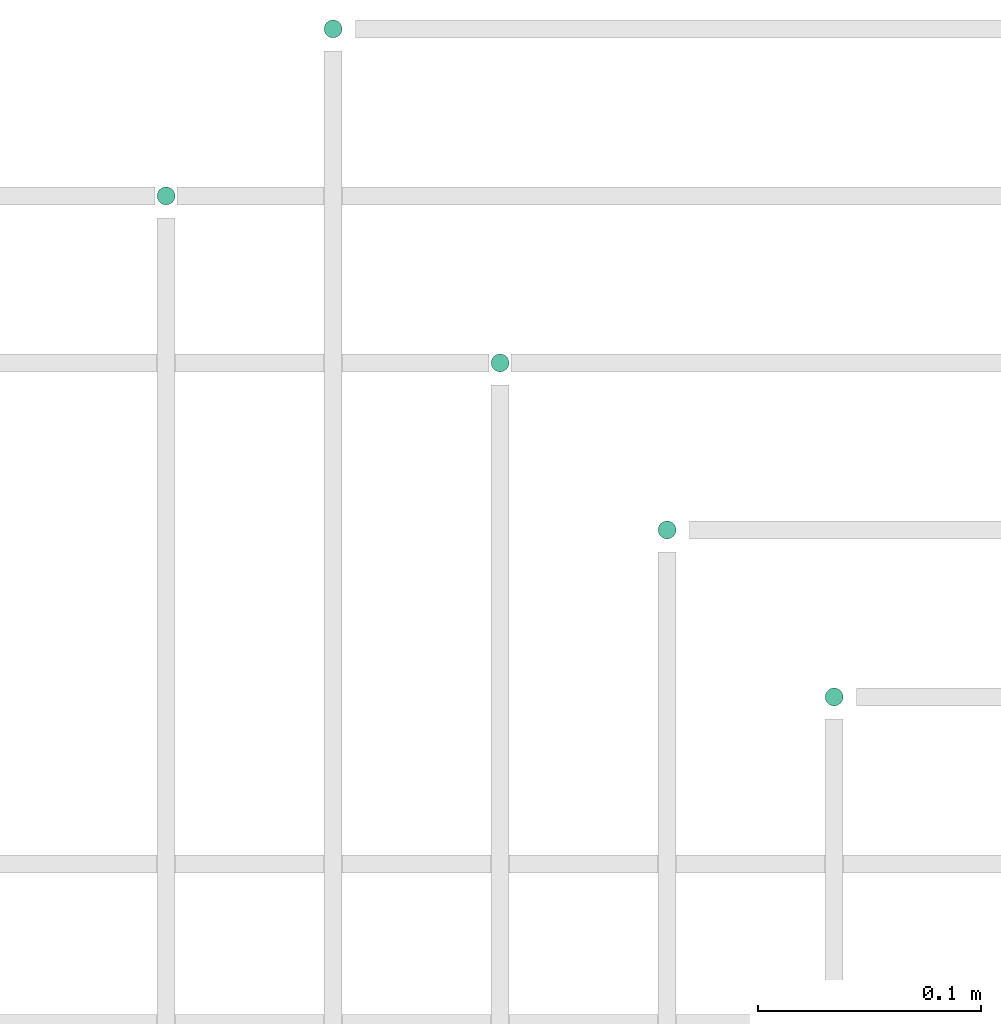
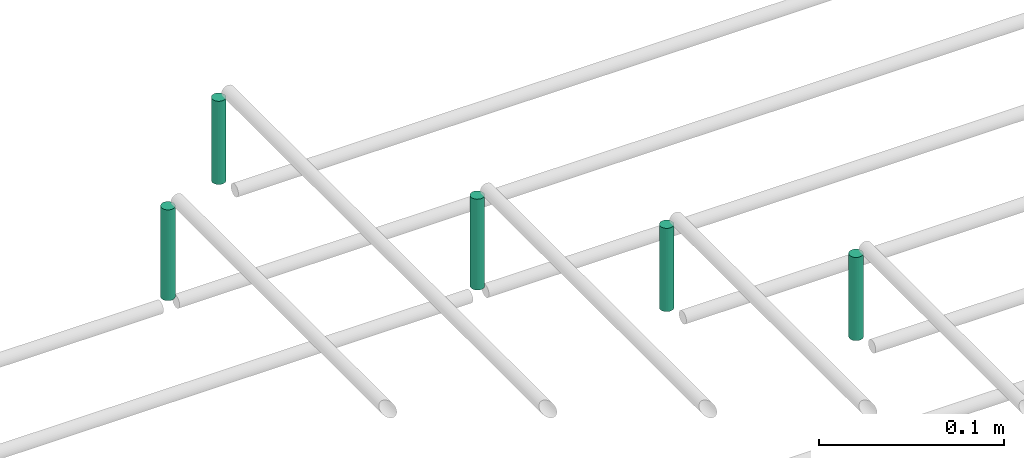
# One storey, part 71 of 89: 5 flow segments.
"""IFC2X3 building model written with IfcOpenShell, lengths in millimetres."""

import ifcopenshell
import ifcopenshell.guid

model = None  # the IFC model being written
_history = None  # IfcOwnerHistory: only IFC2X3 demands one
_inside = {}  # id of a spatial element -> (the spatial element, [elements in it])
_under = {}  # id of a project, library or spatial element -> (it, [spatial elements below it])
_declared = {}  # id of a project -> (the project, [libraries it declares])
_typed = {}  # id of a type object -> (the type object, [elements of that type])
_made_of = {}  # id of a material, layer set ... -> (it, [elements and type objects made of it])


def new_model(schema):
    """Start an empty IFC model of exactly this schema.

    Asked for "IFC4X3", IfcOpenShell would pick the latest addendum, in which some entities
    have other attributes; the version numbers below select the first issue.
    IFC2X3 requires an IfcOwnerHistory on every rooted entity: one is made here for all.
    """
    global model, _history
    if schema == "IFC4X3":
        model = ifcopenshell.file(schema_version=(4, 3, 0, 0))
    else:
        model = ifcopenshell.file(schema=schema)
    _inside.clear()
    _under.clear()
    _declared.clear()
    _typed.clear()
    _made_of.clear()
    _history = None
    if model.schema == "IFC2X3":
        org = make("IfcOrganization", Name="unknown")
        user = make(
            "IfcPersonAndOrganization",
            ThePerson=make("IfcPerson", FamilyName="unknown"),
            TheOrganization=org,
        )
        app = make(
            "IfcApplication",
            ApplicationDeveloper=org,
            Version="unknown",
            ApplicationFullName="unknown",
            ApplicationIdentifier="unknown",
        )
        _history = make(
            "IfcOwnerHistory",
            OwningUser=user,
            OwningApplication=app,
            ChangeAction="ADDED",
            CreationDate=0,
        )
    return model


def make(cls, **values):
    """One entity of the class cls with the attributes given. An attribute that is None is left unset."""
    return model.create_entity(
        cls, **{name: value for name, value in values.items() if value is not None}
    )


def entity(cls, *values):
    """Any entity or typed value of the class cls, its attributes in the order of the schema. None: left unset."""
    e = model.create_entity(cls)
    for i, value in enumerate(values):
        if value is not None:
            e[i] = value
    return e


def rooted(cls, **values):
    """An entity with a GlobalId (a new one), such as an element, a storey or a relation."""
    return make(cls, GlobalId=ifcopenshell.guid.new(), OwnerHistory=_history, **values)


def si_unit(unit_type, name, prefix=None):
    """IfcSIUnit, for example si_unit("LENGTHUNIT", "METRE", prefix="MILLI")."""
    return make("IfcSIUnit", UnitType=unit_type, Prefix=prefix, Name=name)


def converted_unit(unit_type, name, factor, base, dimensions=None, offset=None):
    """IfcConversionBasedUnit, such as the inch: factor (a typed value) times the base unit."""
    return make(
        "IfcConversionBasedUnit"
        if offset is None
        else "IfcConversionBasedUnitWithOffset",
        ConversionOffset=offset,
        Dimensions=None
        if dimensions is None
        else entity("IfcDimensionalExponents", *dimensions),
        UnitType=unit_type,
        Name=name,
        ConversionFactor=make(
            "IfcMeasureWithUnit", ValueComponent=factor, UnitComponent=base
        ),
    )


def derived_unit(unit_type, elements):
    """IfcDerivedUnit: a product of units, each with its exponent."""
    return make(
        "IfcDerivedUnit",
        Elements=[
            make("IfcDerivedUnitElement", Unit=unit, Exponent=power)
            for unit, power in elements
        ],
        UnitType=unit_type,
    )


def assignment(units):
    """IfcUnitAssignment: the units of a project."""
    return None if units is None else make("IfcUnitAssignment", Units=units)


def point(xyz):
    """IfcCartesianPoint."""
    return None if xyz is None else make("IfcCartesianPoint", Coordinates=xyz)


def direction(xyz):
    """IfcDirection."""
    return None if xyz is None else make("IfcDirection", DirectionRatios=xyz)


def frame(location, z_axis=None, x_axis=None):
    """IfcAxis2Placement3D, a coordinate frame: its origin and axes. An axis left out is left unset."""
    return make(
        "IfcAxis2Placement3D",
        Location=point(location),
        Axis=direction(z_axis),
        RefDirection=direction(x_axis),
    )


def frame_2d(location, x_axis=None):
    """IfcAxis2Placement2D, a coordinate frame in the plane: its origin and x axis."""
    return make(
        "IfcAxis2Placement2D", Location=point(location), RefDirection=direction(x_axis)
    )


def origin():
    """The frame at (0, 0, 0) with its axes left unset."""
    return frame((0.0, 0.0, 0.0))


def origin_2d_with_axis():
    """The frame at (0, 0) in the plane with the x axis (1, 0) written out."""
    return frame_2d((0.0, 0.0), x_axis=(1.0, 0.0))


def place(relative_to, where):
    """IfcLocalPlacement: puts the frame where relative to a parent placement (None: the world)."""
    return make(
        "IfcLocalPlacement", PlacementRelTo=relative_to, RelativePlacement=where
    )


def context(
    kind, dimensions, precision=None, world=None, true_north=None, identifier=None
):
    """IfcGeometricRepresentationContext, for example the 3D "Model" context."""
    return make(
        "IfcGeometricRepresentationContext",
        ContextIdentifier=identifier,
        ContextType=kind,
        CoordinateSpaceDimension=dimensions,
        Precision=precision,
        WorldCoordinateSystem=world,
        TrueNorth=true_north,
    )


def subcontext(parent, identifier, kind, view, scale=None):
    """IfcGeometricRepresentationSubContext, for example "Body" below "Model"."""
    return make(
        "IfcGeometricRepresentationSubContext",
        ContextIdentifier=identifier,
        ContextType=kind,
        ParentContext=parent,
        TargetScale=scale,
        TargetView=view,
    )


def project(units=None, contexts=None):
    """IfcProject with its units and contexts."""
    return rooted(
        "IfcProject",
        Name="project",
        RepresentationContexts=contexts,
        UnitsInContext=assignment(units),
    )


def spatial(cls, under=None, at=None, **own):
    """A site, building, storey or space (cls), placed at a placement, below another one or the project."""
    s = rooted(cls, ObjectPlacement=at, **own)
    if under is not None:
        _under.setdefault(under.id(), (under, []))[1].append(s)
    return s


def profile(cls, at=None, kind="AREA", **sizes):
    """A parametric profile (cls). Its sizes go by their IFC names, for example OverallWidth=200.0."""
    return make(cls, ProfileType=kind, Position=at, **sizes)


def circle(**sizes):
    """IfcCircleProfileDef."""
    return profile("IfcCircleProfileDef", **sizes)


def extrude(swept, where, along, depth):
    """IfcExtrudedAreaSolid: the profile swept, set in the frame where, extruded along a direction by depth."""
    return make(
        "IfcExtrudedAreaSolid",
        SweptArea=swept,
        Position=where,
        ExtrudedDirection=direction(along),
        Depth=depth,
    )


def shape(context_of_items, identifier, shape_type, items):
    """IfcShapeRepresentation: the items that make up one representation, for example the "Body"."""
    return make(
        "IfcShapeRepresentation",
        ContextOfItems=context_of_items,
        RepresentationIdentifier=identifier,
        RepresentationType=shape_type,
        Items=items,
    )


def made_of(thing, what):
    """Note that an element or type object is made of a material, layer set ...; save() writes the relation."""
    if what is not None:
        _made_of.setdefault(what.id(), (what, []))[1].append(thing)
    return thing


def type_object(cls, material=None, **own):
    """A type object (cls), such as IfcWallType, which elements share."""
    return made_of(rooted(cls, **own), material)


def element(
    cls,
    number,
    at=None,
    inside=None,
    cuts=None,
    type_object=None,
    material=None,
    context=None,
    identifier="Body",
    shape_type=None,
    held_by="IfcProductDefinitionShape",
    body=None,
    shapes=None,
    **own,
):
    """One element of the class cls, such as IfcWall. Its Tag is "e" and its number.

    at: its placement. inside: the storey or other place that contains it. cuts: it is an
    opening in that element (IfcRelVoidsElement). A single representation is given by context,
    identifier, shape_type and body (its items); several are given by shapes. held_by: the class
    of the entity that holds the representations. save() writes the other relations.
    """
    e = rooted(cls, Tag="e%d" % number, ObjectPlacement=at, **own)
    if body is not None:
        shapes = [shape(context, identifier, shape_type, body)]
    if shapes is not None:
        e.Representation = make(held_by, Representations=shapes)
    if inside is not None:
        _inside.setdefault(inside.id(), (inside, []))[1].append(e)
    if cuts is not None:
        rooted(
            "IfcRelVoidsElement", RelatingBuildingElement=cuts, RelatedOpeningElement=e
        )
    if type_object is not None:
        _typed.setdefault(type_object.id(), (type_object, []))[1].append(e)
    return made_of(e, material)


def aggregate(whole, parts):
    """IfcRelAggregates: a whole, such as a stair, and the parts it consists of."""
    return rooted("IfcRelAggregates", RelatingObject=whole, RelatedObjects=parts)


def save(model, path):
    """Write the relations noted so far, then the file.

    IfcRelAggregates (storeys below a building ...), IfcRelContainedInSpatialStructure (elements
    in a storey), IfcRelDefinesByType, IfcRelAssociatesMaterial and IfcRelDeclares: one each for
    every whole, place, type object, material and project.
    """
    for whole, parts in _under.values():
        aggregate(whole, parts)
    for where, things in _inside.values():
        rooted(
            "IfcRelContainedInSpatialStructure",
            RelatedElements=things,
            RelatingStructure=where,
        )
    for kind, things in _typed.values():
        rooted("IfcRelDefinesByType", RelatedObjects=things, RelatingType=kind)
    for what, things in _made_of.values():
        rooted("IfcRelAssociatesMaterial", RelatedObjects=things, RelatingMaterial=what)
    for by, libraries in _declared.values():
        rooted("IfcRelDeclares", RelatingContext=by, RelatedDefinitions=libraries)
    model.write(path)


model = new_model("IFC2X3")

# Units and contexts
model_context = context("Model", 3, precision=0.01, world=origin(), true_north=direction((6.12303176911189e-17, 1.0)))
body_context = subcontext(model_context, "Body", "Model", "MODEL_VIEW")
ifc_project = project(units=[si_unit("LENGTHUNIT", "METRE", prefix="MILLI"), si_unit("AREAUNIT", "SQUARE_METRE"), si_unit("VOLUMEUNIT", "CUBIC_METRE"), converted_unit("PLANEANGLEUNIT", "DEGREE", entity("IfcRatioMeasure", 0.0174532925199433), si_unit("PLANEANGLEUNIT", "RADIAN"), dimensions=[0, 0, 0, 0, 0, 0, 0]), si_unit("MASSUNIT", "GRAM", prefix="KILO"), derived_unit("MASSDENSITYUNIT", [(si_unit("MASSUNIT", "GRAM", prefix="KILO"), 1), (si_unit("LENGTHUNIT", "METRE"), -3)]), derived_unit("MOMENTOFINERTIAUNIT", [(si_unit("LENGTHUNIT", "METRE"), 4)]), si_unit("TIMEUNIT", "SECOND"), si_unit("FREQUENCYUNIT", "HERTZ"), si_unit("THERMODYNAMICTEMPERATUREUNIT", "DEGREE_CELSIUS"), derived_unit("THERMALTRANSMITTANCEUNIT", [(si_unit("MASSUNIT", "GRAM", prefix="KILO"), 1), (si_unit("THERMODYNAMICTEMPERATUREUNIT", "KELVIN"), -1), (si_unit("TIMEUNIT", "SECOND"), -3)]), derived_unit("VOLUMETRICFLOWRATEUNIT", [(si_unit("LENGTHUNIT", "METRE"), 3), (si_unit("TIMEUNIT", "SECOND"), -1)]), derived_unit("MASSFLOWRATEUNIT", [(si_unit("MASSUNIT", "GRAM", prefix="KILO"), 1), (si_unit("TIMEUNIT", "SECOND"), -1)]), derived_unit("ROTATIONALFREQUENCYUNIT", [(si_unit("TIMEUNIT", "SECOND"), -1)]), si_unit("ELECTRICCURRENTUNIT", "AMPERE"), si_unit("ELECTRICVOLTAGEUNIT", "VOLT"), si_unit("POWERUNIT", "WATT"), si_unit("FORCEUNIT", "NEWTON", prefix="KILO"), si_unit("ILLUMINANCEUNIT", "LUX"), si_unit("LUMINOUSFLUXUNIT", "LUMEN"), si_unit("LUMINOUSINTENSITYUNIT", "CANDELA"), derived_unit("USERDEFINED", [(si_unit("MASSUNIT", "GRAM", prefix="KILO"), -1), (si_unit("LENGTHUNIT", "METRE"), -2), (si_unit("TIMEUNIT", "SECOND"), 3), (si_unit("LUMINOUSFLUXUNIT", "LUMEN"), 1)]), derived_unit("LINEARVELOCITYUNIT", [(si_unit("LENGTHUNIT", "METRE"), 1), (si_unit("TIMEUNIT", "SECOND"), -1)]), si_unit("PRESSUREUNIT", "PASCAL"), derived_unit("USERDEFINED", [(si_unit("LENGTHUNIT", "METRE"), -2), (si_unit("MASSUNIT", "GRAM", prefix="KILO"), 1), (si_unit("TIMEUNIT", "SECOND"), -2)]), derived_unit("LINEARFORCEUNIT", [(si_unit("MASSUNIT", "GRAM", prefix="KILO"), 1), (si_unit("LENGTHUNIT", "METRE"), 1), (si_unit("TIMEUNIT", "SECOND"), -2), (si_unit("LENGTHUNIT", "METRE"), -1)]), derived_unit("PLANARFORCEUNIT", [(si_unit("MASSUNIT", "GRAM", prefix="KILO"), 1), (si_unit("LENGTHUNIT", "METRE"), 1), (si_unit("TIMEUNIT", "SECOND"), -2), (si_unit("LENGTHUNIT", "METRE"), -2)])], contexts=[model_context])

# Site, building, storey
site_placement = place(None, frame((0.0, -0.00077364408347762, 0.0)))
site = spatial("IfcSite", under=ifc_project, at=site_placement, CompositionType="ELEMENT")
building_placement = place(site_placement, origin())
building = spatial("IfcBuilding", under=site, at=building_placement, CompositionType="ELEMENT")
storey_placement = place(building_placement, frame((0.0, 0.0, 24000.0)))
storey = spatial("IfcBuildingStorey", under=building, at=storey_placement, CompositionType="ELEMENT", Elevation=24000.0)

# Flow segments
pipe_segment_type = type_object("IfcPipeSegmentType", PredefinedType="NOTDEFINED")
flow_segment_1_placement = place(storey_placement, frame((45989.1209292421, 18944.4047277642, 2780.0)))
element("IfcFlowSegment", 1, at=flow_segment_1_placement, inside=storey, type_object=pipe_segment_type, context=body_context, shape_type="SweptSolid", body=[
    extrude(circle(Radius=4.0, at=origin_2d_with_axis()), frame((5.59527223591499, 5.59527223591499, 0.0), z_axis=(0.0, 0.0, 1.0), x_axis=(-1.0, 0.0, 0.0)), (0.0, 0.0, 1.0), 59.999999999982),
])
flow_segment_2_placement = place(storey_placement, frame((45839.1209292421, 19019.4047277642, 2780.0)))
element("IfcFlowSegment", 2, at=flow_segment_2_placement, inside=storey, type_object=pipe_segment_type, context=body_context, shape_type="SweptSolid", body=[
    extrude(circle(Radius=4.0, at=origin_2d_with_axis()), frame((5.59527223591499, 5.59527223591499, 0.0), z_axis=(0.0, 0.0, 1.0), x_axis=(-1.0, 0.0, 0.0)), (0.0, 0.0, 1.0), 60.000000000021),
])
flow_segment_3_placement = place(storey_placement, frame((45914.1209292421, 19094.4047277642, 2785.0)))
element("IfcFlowSegment", 3, at=flow_segment_3_placement, inside=storey, type_object=pipe_segment_type, context=body_context, shape_type="SweptSolid", body=[
    extrude(circle(Radius=4.0, at=origin_2d_with_axis()), frame((5.59527223591499, 5.59527223591499, 0.0), z_axis=(0.0, 0.0, 1.0), x_axis=(-1.0, 0.0, 0.0)), (0.0, 0.0, 1.0), 55.0000000000135),
])
for number, where in (
    (4, (46139.1209292421, 18794.4047277642, 2785.0)),
    (5, (46064.1209292421, 18869.4047277642, 2785.0)),
):
    element("IfcFlowSegment", number, at=place(storey_placement, frame(where)), inside=storey, type_object=pipe_segment_type, context=body_context, shape_type="SweptSolid", body=[
        extrude(circle(Radius=4.0, at=origin_2d_with_axis()), frame((5.59527223591499, 5.59527223591499, 0.0), z_axis=(0.0, 0.0, 1.0), x_axis=(-1.0, 0.0, 0.0)), (0.0, 0.0, 1.0), 55.0000000000092),
    ])

save(model, "model.ifc")
